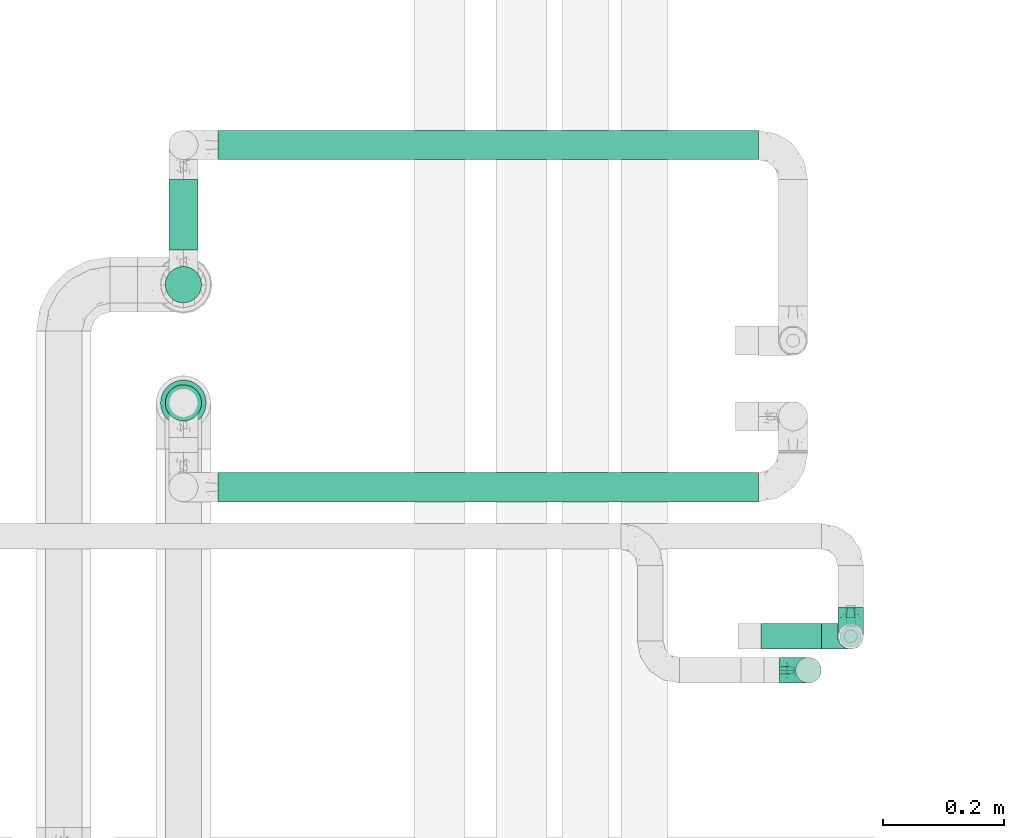
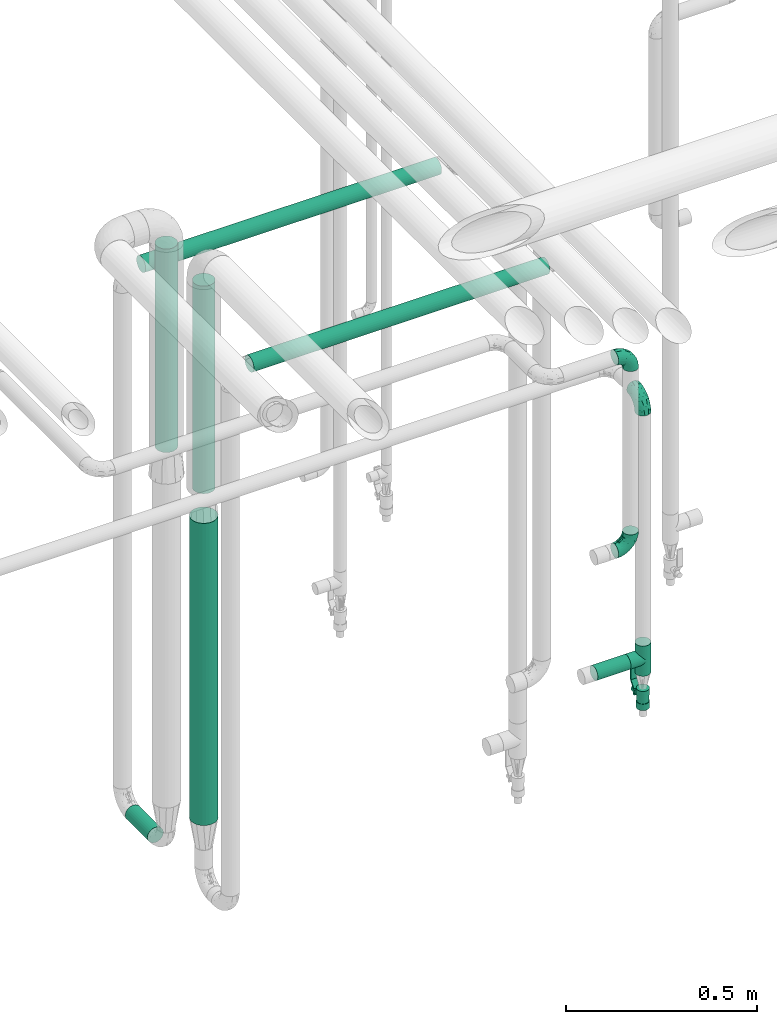
# One storey, part 575 of 824: 7 flow segments, 4 flow fittings, 1 flow controller.
"""IFC2X3 building model written with IfcOpenShell, lengths in millimetres."""

from ifc_helpers import new_model, entity, si_unit, converted_unit, derived_unit, direction, frame, origin, origin_2d_with_axis, place, context, subcontext, project, spatial, polyline, circle, outline, extrude, faceted_brep, source, transform, mapped, material, material_list, type_object, type_shapes, element, save


model = new_model("IFC2X3")

# Units and contexts
model_context = context("Model", 3, precision=0.01, world=origin(), true_north=direction((6.12303176911189e-17, 1.0)))
body_context = subcontext(model_context, "Body", "Model", "MODEL_VIEW")
ifc_project = project(units=[si_unit("LENGTHUNIT", "METRE", prefix="MILLI"), si_unit("AREAUNIT", "SQUARE_METRE"), si_unit("VOLUMEUNIT", "CUBIC_METRE"), converted_unit("PLANEANGLEUNIT", "DEGREE", entity("IfcRatioMeasure", 0.0174532925199433), si_unit("PLANEANGLEUNIT", "RADIAN"), dimensions=[0, 0, 0, 0, 0, 0, 0]), si_unit("MASSUNIT", "GRAM", prefix="KILO"), derived_unit("MASSDENSITYUNIT", [(si_unit("MASSUNIT", "GRAM", prefix="KILO"), 1), (si_unit("LENGTHUNIT", "METRE"), -3)]), derived_unit("MOMENTOFINERTIAUNIT", [(si_unit("LENGTHUNIT", "METRE"), 4)]), si_unit("TIMEUNIT", "SECOND"), si_unit("FREQUENCYUNIT", "HERTZ"), si_unit("THERMODYNAMICTEMPERATUREUNIT", "DEGREE_CELSIUS"), derived_unit("THERMALTRANSMITTANCEUNIT", [(si_unit("MASSUNIT", "GRAM", prefix="KILO"), 1), (si_unit("THERMODYNAMICTEMPERATUREUNIT", "KELVIN"), -1), (si_unit("TIMEUNIT", "SECOND"), -3)]), derived_unit("VOLUMETRICFLOWRATEUNIT", [(si_unit("LENGTHUNIT", "METRE"), 3), (si_unit("TIMEUNIT", "SECOND"), -1)]), derived_unit("MASSFLOWRATEUNIT", [(si_unit("MASSUNIT", "GRAM", prefix="KILO"), 1), (si_unit("TIMEUNIT", "SECOND"), -1)]), derived_unit("ROTATIONALFREQUENCYUNIT", [(si_unit("TIMEUNIT", "SECOND"), -1)]), si_unit("ELECTRICCURRENTUNIT", "AMPERE"), si_unit("ELECTRICVOLTAGEUNIT", "VOLT"), si_unit("POWERUNIT", "WATT"), si_unit("FORCEUNIT", "NEWTON", prefix="KILO"), si_unit("ILLUMINANCEUNIT", "LUX"), si_unit("LUMINOUSFLUXUNIT", "LUMEN"), si_unit("LUMINOUSINTENSITYUNIT", "CANDELA"), derived_unit("USERDEFINED", [(si_unit("MASSUNIT", "GRAM", prefix="KILO"), -1), (si_unit("LENGTHUNIT", "METRE"), -2), (si_unit("TIMEUNIT", "SECOND"), 3), (si_unit("LUMINOUSFLUXUNIT", "LUMEN"), 1)]), derived_unit("LINEARVELOCITYUNIT", [(si_unit("LENGTHUNIT", "METRE"), 1), (si_unit("TIMEUNIT", "SECOND"), -1)]), si_unit("PRESSUREUNIT", "PASCAL"), derived_unit("USERDEFINED", [(si_unit("LENGTHUNIT", "METRE"), -2), (si_unit("MASSUNIT", "GRAM", prefix="KILO"), 1), (si_unit("TIMEUNIT", "SECOND"), -2)]), derived_unit("LINEARFORCEUNIT", [(si_unit("MASSUNIT", "GRAM", prefix="KILO"), 1), (si_unit("LENGTHUNIT", "METRE"), 1), (si_unit("TIMEUNIT", "SECOND"), -2), (si_unit("LENGTHUNIT", "METRE"), -1)]), derived_unit("PLANARFORCEUNIT", [(si_unit("MASSUNIT", "GRAM", prefix="KILO"), 1), (si_unit("LENGTHUNIT", "METRE"), 1), (si_unit("TIMEUNIT", "SECOND"), -2), (si_unit("LENGTHUNIT", "METRE"), -2)])], contexts=[model_context])

# Site, building, storey
site_placement = place(None, origin())
site = spatial("IfcSite", under=ifc_project, at=site_placement, CompositionType="ELEMENT")
building_placement = place(site_placement, origin())
building = spatial("IfcBuilding", under=site, at=building_placement, CompositionType="ELEMENT")
storey_placement = place(building_placement, frame((0.0, 0.0, 28200.0)))
storey = spatial("IfcBuildingStorey", under=building, at=storey_placement, CompositionType="ELEMENT", Elevation=28200.0)

# Flow segments
pipe_segment_type = type_object("IfcPipeSegmentType", PredefinedType="NOTDEFINED")
flow_segment_1_placement = place(storey_placement, frame((17890.7, 15495.65, 1662.32)))
element("IfcFlowSegment", 1, at=flow_segment_1_placement, inside=storey, type_object=pipe_segment_type, context=body_context, shape_type="SweptSolid", body=[
    extrude(circle(Radius=30.0, at=origin_2d_with_axis()), frame((31.6, 31.6, 0.0)), (0.0, 0.0, 1.0), 661.683633817541),
])
flow_segment_2_placement = place(storey_placement, frame((17890.7, 15690.85, 1675.32)))
element("IfcFlowSegment", 2, at=flow_segment_2_placement, inside=storey, type_object=pipe_segment_type, context=body_context, shape_type="SweptSolid", body=[
    extrude(circle(Radius=30.0, at=origin_2d_with_axis()), frame((31.6, 31.6, 0.0)), (0.0, 0.0, 1.0), 648.839896833194),
])
flow_segment_3_placement = place(storey_placement, frame((17896.7, 15779.44, 375.34)))
element("IfcFlowSegment", 3, at=flow_segment_3_placement, inside=storey, type_object=pipe_segment_type, context=body_context, shape_type="SweptSolid", body=[
    extrude(circle(Radius=24.0, at=origin_2d_with_axis()), frame((25.6, 0.0, 25.6), z_axis=(0.0, 1.0, 0.0), x_axis=(-1.0, 0.0, 0.0)), (0.0, 0.0, 1.0), 116.645270208734),
])
flow_segment_4_placement = place(storey_placement, frame((17979.29, 15927.49, 2070.34)))
element("IfcFlowSegment", 4, at=flow_segment_4_placement, inside=storey, type_object=pipe_segment_type, context=body_context, shape_type="SweptSolid", body=[
    extrude(circle(Radius=24.0, at=origin_2d_with_axis()), frame((0.0, 25.6, 25.6), z_axis=(1.0, 0.0, 0.0), x_axis=(0.0, -1.0, 0.0)), (0.0, 0.0, 1.0), 892.764504538315),
])
flow_segment_5_placement = place(storey_placement, frame((17979.29, 15362.39, 2095.34)))
element("IfcFlowSegment", 5, at=flow_segment_5_placement, inside=storey, type_object=pipe_segment_type, context=body_context, shape_type="SweptSolid", body=[
    extrude(circle(Radius=24.0, at=origin_2d_with_axis()), frame((0.0, 25.6, 25.6), z_axis=(1.0, 0.0, 0.0), x_axis=(0.0, -1.0, 0.0)), (0.0, 0.0, 1.0), 892.764504538304),
])
flow_segment_6_placement = place(storey_placement, frame((17882.95, 15487.9, 609.94)))
element("IfcFlowSegment", 6, at=flow_segment_6_placement, inside=storey, type_object=pipe_segment_type, context=body_context, shape_type="SweptSolid", body=[
    extrude(circle(Radius=37.75, at=origin_2d_with_axis()), frame((39.35, 39.35, 0.0), z_axis=(0.0, 0.0, 1.0), x_axis=(-1.0, 0.0, 0.0)), (0.0, 0.0, 1.0), 963.376941605387),
])
flow_segment_7_placement = place(storey_placement, frame((18876.06, 15119.04, 947.36)))
element("IfcFlowSegment", 7, at=flow_segment_7_placement, inside=storey, type_object=pipe_segment_type, context=body_context, shape_type="SweptSolid", body=[
    extrude(circle(Radius=21.15, at=origin_2d_with_axis()), frame((0.0, 22.75, 22.75), z_axis=(1.0, 0.0, 0.0), x_axis=(0.0, 1.0, 0.0)), (0.0, 0.0, 1.0), 100.000000000001),
])

# Flow controller
ifc_material = material()
ifc_material_list = material_list([ifc_material, ifc_material, ifc_material, ifc_material, ifc_material])
valve_type = type_object("IfcValveType", PredefinedType="NOTDEFINED", material=ifc_material_list)
shared_shape_1 = source(origin(), body_context, "Body", "SweptSolid", [
    extrude(circle(Radius=17.5, at=origin_2d_with_axis()), frame((-30.5, 0.0, 0.0), z_axis=(1.0, 0.0, 0.0), x_axis=(0.0, 1.0, 0.0)), (0.0, 0.0, 1.0), 20.3333333333333),
    extrude(circle(Radius=16.0, at=origin_2d_with_axis()), frame((-10.17, 0.0, 0.0), z_axis=(1.0, 0.0, 0.0), x_axis=(0.0, 1.0, 0.0)), (0.0, 0.0, 1.0), 20.3333333333333),
    extrude(circle(Radius=17.5, at=origin_2d_with_axis()), frame((10.17, 0.0, 0.0), z_axis=(1.0, 0.0, 0.0), x_axis=(0.0, 1.0, 0.0)), (0.0, 0.0, 1.0), 20.3333333333333),
    extrude(outline(polyline([(-38.75, -5.0), (-38.75, -10.0), (-17.92, -10.0), (2.08, 5.0), (56.25, 5.0), (56.25, 10.0), (0.42, 10.0), (-19.58, -5.0), (-38.75, -5.0)])), frame((28.75, -8.75, 41.5), z_axis=(0.0, -1.0, 0.0), x_axis=(1.0, 0.0, 0.0)), (0.0, 0.0, -1.0), 17.5),
    extrude(circle(Radius=8.0, at=origin_2d_with_axis()), origin(), (0.0, 0.0, 1.0), 49.0),
])
type_shapes(valve_type, [shared_shape_1])
flow_controller_placement = place(storey_placement, frame((19024.06, 15141.79, 840.61), z_axis=(0.0, 1.0, 0.0), x_axis=(0.0, 0.0, 1.0)))
element("IfcFlowController", 8, at=flow_controller_placement, inside=storey, type_object=valve_type, material=ifc_material, context=body_context, shape_type="MappedRepresentation", body=[
    mapped(shared_shape_1, transform((0.0, 0.0, 0.0), scale=1.0)),
])

# Flow fittings
pipe_fitting_type_1 = type_object("IfcPipeFittingType", PredefinedType="NOTDEFINED", material=ifc_material)
shared_shape_2 = source(origin(), body_context, "Body", "Brep", [
    faceted_brep([(-48.0, 10.6, -18.36), (-48.0, 5.49, -20.48), (-48.0, 0.0, -21.2), (-48.0, -5.49, -20.48), (-48.0, -10.6, -18.36), (-48.0, -14.99, -14.99), (-48.0, -18.36, -10.6), (-48.0, -20.48, -5.49), (-48.0, -21.2, 0.0), (-48.0, -20.48, 5.49), (-48.0, -18.36, 10.6), (-48.0, -14.99, 14.99), (-48.0, -10.6, 18.36), (-48.0, -5.49, 20.48), (-48.0, 0.0, 21.2), (-48.0, 5.49, 20.48), (-48.0, 10.6, 18.36), (-48.0, 14.99, 14.99), (-48.0, 18.36, 10.6), (-48.0, 20.48, 5.49), (-48.0, 21.2, 0.0), (-48.0, 20.48, -5.49), (-48.0, 18.36, -10.6), (-48.0, 14.99, -14.99), (0.0, 48.0, -21.2), (-5.49, 48.0, -20.48), (-10.6, 48.0, -18.36), (-14.99, 48.0, -14.99), (-18.36, 48.0, -10.6), (-20.48, 48.0, -5.49), (-21.2, 48.0, 0.0), (-20.48, 48.0, 5.49), (-18.36, 48.0, 10.6), (-14.99, 48.0, 14.99), (-10.6, 48.0, 18.36), (-5.49, 48.0, 20.48), (0.0, 48.0, 21.2), (5.49, 48.0, 20.48), (10.6, 48.0, 18.36), (14.99, 48.0, 14.99), (18.36, 48.0, 10.6), (20.48, 48.0, 5.49), (21.2, 48.0, 0.0), (20.48, 48.0, -5.49), (18.36, 48.0, -10.6), (14.99, 48.0, -14.99), (10.6, 48.0, -18.36), (5.49, 48.0, -20.48), (-35.25, -16.22, 12.01), (-34.76, -18.57, 0.0), (-20.87, -12.37, 10.9), (-31.49, -11.78, 15.9), (-37.0, -2.58, 20.86), (-33.89, 3.62, 21.15), (-31.81, -18.14, 6.76), (-5.78, 5.78, 17.67), (-19.42, -4.1, 17.86), (-9.6, -3.39, 13.73), (-35.44, -7.73, 19.13), (11.78, 31.49, 15.9), (-5.93, -5.46, 6.95), (-18.45, -13.78, 5.46), (-10.29, -8.43, 0.0), (-24.6, 0.55, 20.62), (-37.28, 17.94, 13.81), (-33.38, 22.85, 9.59), (-41.46, 20.06, 8.75), (-29.51, 20.45, 15.16), (-15.04, 10.79, 21.13), (-7.08, 16.98, 20.93), (-8.39, 23.51, 21.15), (-40.86, 13.03, 17.26), (-8.05, 41.26, 19.83), (-3.21, 35.97, 21.14), (8.53, 19.66, 14.74), (4.1, 19.42, 17.86), (-37.72, 22.66, 4.78), (-37.07, 8.58, 19.98), (-13.0, 5.43, 19.97), (-3.78, 13.93, 19.7), (3.02, 8.69, 13.43), (-2.27, -0.05, 10.65), (6.22, 6.99, 7.09), (-22.25, 34.6, 9.45), (18.14, 31.81, 6.76), (16.22, 35.25, 12.01), (12.37, 20.87, 10.9), (7.73, 35.44, 19.13), (-21.52, -15.93, 0.0), (2.58, 37.0, 20.86), (18.57, 34.76, 0.0), (13.78, 18.45, 5.46), (15.93, 21.52, 0.0), (-20.03, -8.54, 14.9), (-28.6, 28.6, 5.16), (-24.79, 34.6, 0.0), (-34.6, 24.79, 0.0), (-22.81, 37.41, 4.68), (-23.36, 26.33, 14.79), (-13.68, 37.05, 17.49), (-17.72, 38.12, 13.73), (-26.25, 27.3, 11.24), (-9.71, 32.34, 20.14), (-17.26, 25.6, 18.71), (-26.33, 9.99, 20.77), (-24.06, 6.05, 21.2), (-25.02, 15.46, 19.56), (-24.3, 20.72, 17.57), (-31.95, 15.23, 17.8), (-13.53, 24.7, 20.21), (-17.6, 17.6, 20.6), (-0.55, 24.6, 20.62), (-11.41, -7.48, 10.43), (0.93, -0.93, 0.0), (8.43, 10.29, 0.0), (-11.41, -7.48, -10.43), (-20.1, -8.84, -14.66), (-9.6, -3.39, -13.73), (7.73, 35.44, -19.13), (4.1, 19.42, -17.86), (-0.55, 24.6, -20.62), (-38.12, 17.72, -13.73), (-37.05, 13.68, -17.49), (-32.34, 9.71, -20.14), (-41.26, 8.05, -19.83), (-37.41, 22.81, -4.68), (-23.51, 8.39, -21.15), (-35.97, 3.21, -21.14), (-28.6, 28.6, -5.16), (-31.81, -18.14, -6.76), (-18.45, -13.78, -5.46), (-25.6, 17.26, -18.71), (-19.42, -4.1, -17.86), (-17.94, 37.28, -13.81), (-22.85, 33.38, -9.59), (-20.06, 41.46, -8.75), (-31.49, -11.78, -15.9), (-35.25, -16.22, -12.01), (8.53, 19.66, -14.74), (11.78, 31.49, -15.9), (-9.99, 26.33, -20.77), (-6.05, 24.06, -21.2), (-10.79, 15.04, -21.13), (-37.0, -2.58, -20.86), (-16.98, 7.08, -20.93), (-5.43, 13.0, -19.97), (-13.93, 3.78, -19.7), (-20.87, -12.37, -10.9), (-26.33, 23.36, -14.79), (-22.66, 37.72, -4.78), (13.78, 18.45, -5.46), (18.14, 31.81, -6.76), (-15.46, 25.02, -19.56), (-20.72, 24.3, -17.57), (16.22, 35.25, -12.01), (-13.03, 40.86, -17.26), (-8.58, 37.07, -19.98), (2.58, 37.0, -20.86), (-3.62, 33.89, -21.15), (-34.6, 22.25, -9.45), (6.22, 6.99, -7.09), (-20.45, 29.51, -15.16), (-35.44, -7.73, -19.13), (12.37, 20.87, -10.9), (-27.3, 26.25, -11.24), (-15.23, 31.95, -17.8), (-24.7, 13.53, -20.21), (-24.6, 0.55, -20.62), (-5.78, 5.78, -17.67), (-17.6, 17.6, -20.6), (3.02, 8.69, -13.43), (-5.93, -5.46, -6.95), (-2.27, -0.05, -10.65)], [[[0, 1, 2, 3, 4, 5, 6, 7, 8, 9, 10, 11, 12, 13, 14, 15, 16, 17, 18, 19, 20, 21, 22, 23]], [[24, 25, 26, 27, 28, 29, 30, 31, 32, 33, 34, 35, 36, 37, 38, 39, 40, 41, 42, 43, 44, 45, 46, 47]], [[10, 48, 11]], [[9, 8, 49]], [[48, 50, 51]], [[14, 52, 53]], [[10, 54, 48]], [[9, 54, 10]], [[55, 56, 57]], [[51, 12, 11]], [[51, 58, 12]], [[59, 39, 38]], [[60, 61, 62]], [[58, 56, 63]], [[64, 65, 66]], [[67, 65, 64]], [[68, 69, 70]], [[16, 71, 17]], [[13, 52, 14]], [[35, 72, 73]], [[14, 53, 15]], [[17, 64, 18]], [[74, 59, 75]], [[20, 19, 76]], [[66, 19, 18]], [[77, 15, 53]], [[15, 77, 16]], [[69, 78, 79]], [[80, 81, 82]], [[32, 31, 83]], [[84, 85, 86]], [[59, 87, 75]], [[61, 54, 88]], [[36, 89, 37]], [[84, 41, 40]], [[36, 35, 73]], [[90, 41, 84]], [[40, 39, 85]], [[12, 58, 13]], [[85, 84, 40]], [[91, 84, 86]], [[84, 92, 90]], [[87, 38, 37]], [[93, 56, 51]], [[65, 94, 76]], [[94, 95, 96]], [[84, 91, 92]], [[95, 97, 30]], [[98, 99, 100]], [[76, 94, 96]], [[101, 98, 83]], [[100, 99, 33]], [[102, 70, 73]], [[103, 102, 99]], [[94, 97, 95]], [[72, 99, 102]], [[72, 35, 34]], [[34, 33, 99]], [[9, 49, 54]], [[87, 59, 38]], [[104, 105, 68]], [[106, 103, 107]], [[106, 77, 104]], [[71, 64, 17]], [[108, 107, 67]], [[33, 32, 100]], [[109, 103, 110]], [[102, 109, 70]], [[89, 73, 111]], [[50, 48, 54]], [[51, 11, 48]], [[56, 58, 51]], [[88, 54, 49]], [[52, 58, 63]], [[50, 112, 93]], [[56, 55, 78]], [[39, 59, 85]], [[86, 85, 59]], [[89, 87, 37]], [[42, 41, 90]], [[111, 79, 75]], [[111, 75, 87]], [[75, 55, 80]], [[104, 77, 53]], [[71, 77, 108]], [[32, 83, 100]], [[98, 100, 83]], [[99, 98, 103]], [[106, 107, 108]], [[68, 70, 110]], [[111, 73, 70]], [[68, 110, 104]], [[68, 63, 78]], [[57, 93, 112]], [[80, 55, 57]], [[61, 50, 54]], [[80, 82, 86]], [[81, 57, 112]], [[74, 86, 59]], [[60, 113, 82]], [[82, 114, 91]], [[101, 94, 65]], [[97, 94, 83]], [[73, 89, 36]], [[87, 89, 111]], [[58, 52, 13]], [[53, 52, 63]], [[104, 53, 105]], [[106, 104, 110]], [[20, 76, 96]], [[76, 19, 66]], [[103, 106, 110]], [[77, 106, 108]], [[103, 98, 107]], [[67, 107, 98]], [[67, 98, 101]], [[108, 67, 64]], [[53, 63, 105]], [[63, 68, 105]], [[83, 31, 97]], [[30, 97, 31]], [[62, 113, 60]], [[112, 61, 60]], [[61, 88, 62]], [[86, 82, 91]], [[56, 78, 63]], [[114, 82, 113]], [[114, 92, 91]], [[79, 78, 55]], [[75, 79, 55]], [[69, 79, 111]], [[70, 69, 111]], [[78, 69, 68]], [[77, 71, 16]], [[64, 71, 108]], [[64, 66, 18]], [[76, 66, 65]], [[99, 72, 34]], [[73, 72, 102]], [[94, 101, 83]], [[67, 101, 65]], [[75, 80, 74]], [[80, 86, 74]], [[70, 109, 110]], [[102, 103, 109]], [[50, 93, 51]], [[57, 56, 93]], [[61, 112, 50]], [[81, 112, 60]], [[82, 81, 60]], [[80, 57, 81]], [[115, 116, 117]], [[118, 119, 120]], [[121, 122, 23]], [[123, 124, 122]], [[96, 125, 20]], [[123, 126, 127]], [[128, 96, 95]], [[129, 130, 88]], [[123, 122, 131]], [[116, 132, 117]], [[133, 134, 135]], [[0, 124, 1]], [[5, 136, 137]], [[138, 119, 139]], [[129, 88, 49]], [[140, 141, 142]], [[6, 5, 137]], [[46, 118, 47]], [[143, 3, 2]], [[144, 145, 146]], [[6, 129, 7]], [[129, 137, 147]], [[127, 2, 1]], [[148, 122, 121]], [[128, 125, 96]], [[134, 128, 149]], [[95, 149, 128]], [[150, 151, 92]], [[30, 29, 149]], [[152, 131, 153]], [[27, 133, 28]], [[154, 45, 44]], [[136, 5, 4]], [[27, 26, 155]], [[156, 26, 25]], [[24, 157, 158]], [[24, 47, 157]], [[22, 21, 159]], [[160, 150, 114]], [[134, 133, 161]], [[142, 144, 126]], [[46, 139, 118]], [[162, 136, 4]], [[156, 25, 158]], [[1, 124, 127]], [[115, 147, 116]], [[45, 154, 139]], [[139, 46, 45]], [[154, 163, 139]], [[162, 4, 3]], [[42, 90, 43]], [[130, 129, 147]], [[49, 7, 129]], [[43, 151, 44]], [[0, 23, 122]], [[24, 158, 25]], [[136, 162, 132]], [[135, 29, 28]], [[43, 90, 151]], [[164, 148, 159]], [[152, 156, 140]], [[155, 133, 27]], [[165, 153, 161]], [[23, 22, 121]], [[123, 131, 166]], [[123, 166, 126]], [[143, 127, 167]], [[147, 137, 136]], [[8, 7, 49]], [[129, 6, 137]], [[143, 162, 3]], [[167, 146, 132]], [[167, 132, 162]], [[132, 168, 117]], [[44, 151, 154]], [[92, 151, 90]], [[163, 154, 151]], [[119, 118, 139]], [[157, 118, 120]], [[138, 139, 163]], [[119, 168, 145]], [[140, 156, 158]], [[155, 156, 165]], [[22, 159, 121]], [[148, 121, 159]], [[122, 148, 131]], [[152, 153, 165]], [[142, 126, 169]], [[167, 127, 126]], [[142, 169, 140]], [[142, 120, 145]], [[168, 170, 117]], [[160, 171, 172]], [[115, 172, 171]], [[171, 62, 130]], [[119, 170, 168]], [[170, 163, 160]], [[150, 163, 151]], [[113, 171, 160]], [[164, 128, 134]], [[125, 128, 159]], [[127, 143, 2]], [[162, 143, 167]], [[118, 157, 47]], [[158, 157, 120]], [[140, 158, 141]], [[152, 140, 169]], [[30, 149, 95]], [[149, 29, 135]], [[131, 152, 169]], [[156, 152, 165]], [[131, 148, 153]], [[161, 153, 148]], [[161, 148, 164]], [[165, 161, 133]], [[158, 120, 141]], [[120, 142, 141]], [[159, 21, 125]], [[20, 125, 21]], [[115, 130, 147]], [[114, 113, 160]], [[62, 171, 113]], [[62, 88, 130]], [[160, 163, 150]], [[150, 92, 114]], [[119, 145, 120]], [[146, 145, 168]], [[132, 146, 168]], [[144, 146, 167]], [[126, 144, 167]], [[145, 144, 142]], [[156, 155, 26]], [[133, 155, 165]], [[133, 135, 28]], [[149, 135, 134]], [[122, 124, 0]], [[127, 124, 123]], [[128, 164, 159]], [[161, 164, 134]], [[163, 170, 138]], [[170, 119, 138]], [[131, 169, 166]], [[126, 166, 169]], [[147, 136, 116]], [[132, 116, 136]], [[172, 115, 117]], [[130, 115, 171]], [[117, 170, 172]], [[160, 172, 170]]]),
])
type_shapes(pipe_fitting_type_1, [shared_shape_2])
for number, where, z_axis, x_axis in (
    (9, (19024.06, 15141.79, 1800.0), (1.0, 0.0, 0.0), (0.0, -1.0, 0.0)),
    (10, (18954.46, 15085.74, 1383.37), (0.0, -1.0, 0.0), (1.0, 0.0, 0.0)),
    (11, (18954.46, 15085.74, 2000.0), (0.0, -1.0, 0.0), (0.0, 0.0, 1.0)),
):
    element("IfcFlowFitting", number, at=place(storey_placement, frame(where, z_axis=z_axis, x_axis=x_axis)), inside=storey, type_object=pipe_fitting_type_1, material=ifc_material, context=body_context, shape_type="MappedRepresentation", body=[
        mapped(shared_shape_2, transform((0.0, 0.0, 0.0), scale=1.0)),
    ])
pipe_fitting_type_2 = type_object("IfcPipeFittingType", PredefinedType="NOTDEFINED", material=ifc_material)
shared_shape_3 = source(origin(), body_context, "Body", "Brep", [
    faceted_brep([(-48.0, 10.6, -18.36), (-48.0, 5.49, -20.48), (-48.0, 0.0, -21.2), (-48.0, -5.49, -20.48), (-48.0, -10.6, -18.36), (-48.0, -14.99, -14.99), (-48.0, -18.36, -10.6), (-48.0, -20.48, -5.49), (-48.0, -21.2, 0.0), (-48.0, -20.48, 5.49), (-48.0, -18.36, 10.6), (-48.0, -14.99, 14.99), (-48.0, -10.6, 18.36), (-48.0, -5.49, 20.48), (-48.0, 0.0, 21.2), (-48.0, 5.49, 20.48), (-48.0, 10.6, 18.36), (-48.0, 14.99, 14.99), (-48.0, 18.36, 10.6), (-48.0, 20.48, 5.49), (-48.0, 21.2, 0.0), (-48.0, 20.48, -5.49), (-48.0, 18.36, -10.6), (-48.0, 14.99, -14.99), (48.0, 0.0, -21.2), (48.0, 5.49, -20.48), (48.0, 10.6, -18.36), (48.0, 14.99, -14.99), (48.0, 18.36, -10.6), (48.0, 20.48, -5.49), (48.0, 21.2, 0.0), (48.0, 20.48, 5.49), (48.0, 18.36, 10.6), (48.0, 14.99, 14.99), (48.0, 10.6, 18.36), (48.0, 5.49, 20.48), (48.0, 0.0, 21.2), (48.0, -5.49, 20.48), (48.0, -10.6, 18.36), (48.0, -14.99, 14.99), (48.0, -18.36, 10.6), (48.0, -20.48, 5.49), (48.0, -21.2, 0.0), (48.0, -20.48, -5.49), (48.0, -18.36, -10.6), (48.0, -14.99, -14.99), (48.0, -10.6, -18.36), (48.0, -5.49, -20.48), (20.43, -20.43, 5.66), (21.2, -21.2, 0.0), (-21.2, -21.2, 0.0), (18.35, -18.35, 10.62), (11.88, -11.88, 17.56), (15.38, -15.38, 14.59), (-20.43, -20.43, 5.66), (-18.35, -18.35, 10.62), (-15.38, -15.38, 14.59), (-11.88, -11.88, 17.56), (-8.06, -8.06, 19.61), (8.06, -8.06, 19.61), (4.07, -4.07, 20.81), (0.0, 0.0, 21.2), (-4.07, -4.07, 20.81), (4.07, -4.07, -20.81), (0.0, 0.0, -21.2), (-4.07, -4.07, -20.81), (-8.06, -8.06, -19.61), (8.06, -8.06, -19.61), (11.88, -11.88, -17.56), (15.38, -15.38, -14.59), (18.35, -18.35, -10.62), (20.43, -20.43, -5.66), (-11.88, -11.88, -17.56), (-15.38, -15.38, -14.59), (-20.43, -20.43, -5.66), (-18.35, -18.35, -10.62), (0.0, -48.0, -21.2), (5.49, -48.0, -20.48), (10.6, -48.0, -18.36), (14.99, -48.0, -14.99), (18.36, -48.0, -10.6), (20.48, -48.0, -5.49), (21.2, -48.0, 0.0), (20.48, -48.0, 5.49), (18.36, -48.0, 10.6), (14.99, -48.0, 14.99), (10.6, -48.0, 18.36), (5.49, -48.0, 20.48), (0.0, -48.0, 21.2), (-5.49, -48.0, 20.48), (-10.6, -48.0, 18.36), (-14.99, -48.0, 14.99), (-18.36, -48.0, 10.6), (-20.48, -48.0, 5.49), (-21.2, -48.0, 0.0), (-20.48, -48.0, -5.49), (-18.36, -48.0, -10.6), (-14.99, -48.0, -14.99), (-10.6, -48.0, -18.36), (-5.49, -48.0, -20.48)], [[[0, 1, 2, 3, 4, 5, 6, 7, 8, 9, 10, 11, 12, 13, 14, 15, 16, 17, 18, 19, 20, 21, 22, 23]], [[24, 25, 26, 27, 28, 29, 30, 31, 32, 33, 34, 35, 36, 37, 38, 39, 40, 41, 42, 43, 44, 45, 46, 47]], [[41, 40, 48]], [[42, 41, 49]], [[50, 9, 8]], [[49, 41, 48]], [[40, 51, 48]], [[39, 38, 52]], [[51, 40, 53]], [[52, 53, 39]], [[53, 40, 39]], [[50, 54, 9]], [[9, 54, 10]], [[54, 55, 10]], [[56, 57, 11]], [[11, 10, 56]], [[11, 57, 12]], [[56, 10, 55]], [[12, 57, 58]], [[52, 38, 59]], [[60, 36, 61]], [[62, 61, 14]], [[59, 37, 60]], [[37, 59, 38]], [[60, 37, 36]], [[61, 36, 35, 15, 14]], [[32, 31, 19, 18]], [[17, 16, 34, 33]], [[18, 17, 33, 32]], [[35, 34, 16, 15]], [[20, 19, 31, 30]], [[62, 13, 58]], [[13, 62, 14]], [[58, 13, 12]], [[27, 23, 22, 28]], [[22, 21, 29, 28]], [[0, 23, 27, 26]], [[20, 30, 29, 21]], [[24, 47, 63]], [[24, 64, 2, 1, 25]], [[64, 24, 63]], [[2, 64, 65]], [[26, 25, 1, 0]], [[65, 66, 3]], [[2, 65, 3]], [[66, 4, 3]], [[63, 47, 67]], [[46, 45, 68]], [[69, 68, 45]], [[44, 70, 69]], [[69, 45, 44]], [[46, 68, 67]], [[43, 42, 49]], [[7, 50, 8]], [[43, 71, 44]], [[71, 43, 49]], [[44, 71, 70]], [[72, 4, 66]], [[72, 5, 4]], [[5, 72, 73]], [[5, 73, 6]], [[74, 50, 7]], [[75, 74, 6]], [[74, 7, 6]], [[75, 6, 73]], [[46, 67, 47]], [[76, 77, 78, 79, 80, 81, 82, 83, 84, 85, 86, 87, 88, 89, 90, 91, 92, 93, 94, 95, 96, 97, 98, 99]], [[50, 94, 93]], [[54, 50, 93]], [[91, 90, 57]], [[56, 92, 91]], [[54, 93, 92]], [[58, 90, 89]], [[55, 54, 92]], [[56, 55, 92]], [[58, 57, 90]], [[88, 61, 62]], [[58, 89, 62]], [[56, 91, 57]], [[62, 89, 88]], [[60, 88, 87]], [[86, 59, 87]], [[84, 83, 48]], [[53, 85, 84]], [[52, 86, 85]], [[49, 83, 82]], [[59, 60, 87]], [[52, 59, 86]], [[49, 48, 83]], [[51, 53, 84]], [[48, 51, 84]], [[52, 85, 53]], [[88, 60, 61]], [[82, 81, 49]], [[71, 49, 81]], [[69, 80, 79]], [[79, 78, 68]], [[71, 81, 80]], [[67, 78, 77]], [[70, 71, 80]], [[69, 70, 80]], [[67, 68, 78]], [[76, 64, 63]], [[67, 77, 63]], [[69, 79, 68]], [[63, 77, 76]], [[65, 76, 99]], [[98, 66, 99]], [[96, 95, 74]], [[73, 97, 96]], [[72, 98, 97]], [[50, 95, 94]], [[66, 65, 99]], [[72, 66, 98]], [[50, 74, 95]], [[75, 73, 96]], [[74, 75, 96]], [[72, 97, 73]], [[76, 65, 64]]]),
])
type_shapes(pipe_fitting_type_2, [shared_shape_3])
flow_fitting_placement = place(storey_placement, frame((19024.06, 15141.79, 970.11), z_axis=(0.0, 1.0, 0.0), x_axis=(0.0, 0.0, 1.0)))
element("IfcFlowFitting", 12, at=flow_fitting_placement, inside=storey, type_object=pipe_fitting_type_2, material=ifc_material, context=body_context, shape_type="MappedRepresentation", body=[
    mapped(shared_shape_3, transform((0.0, 0.0, 0.0), scale=1.0)),
])

save(model, "model.ifc")
